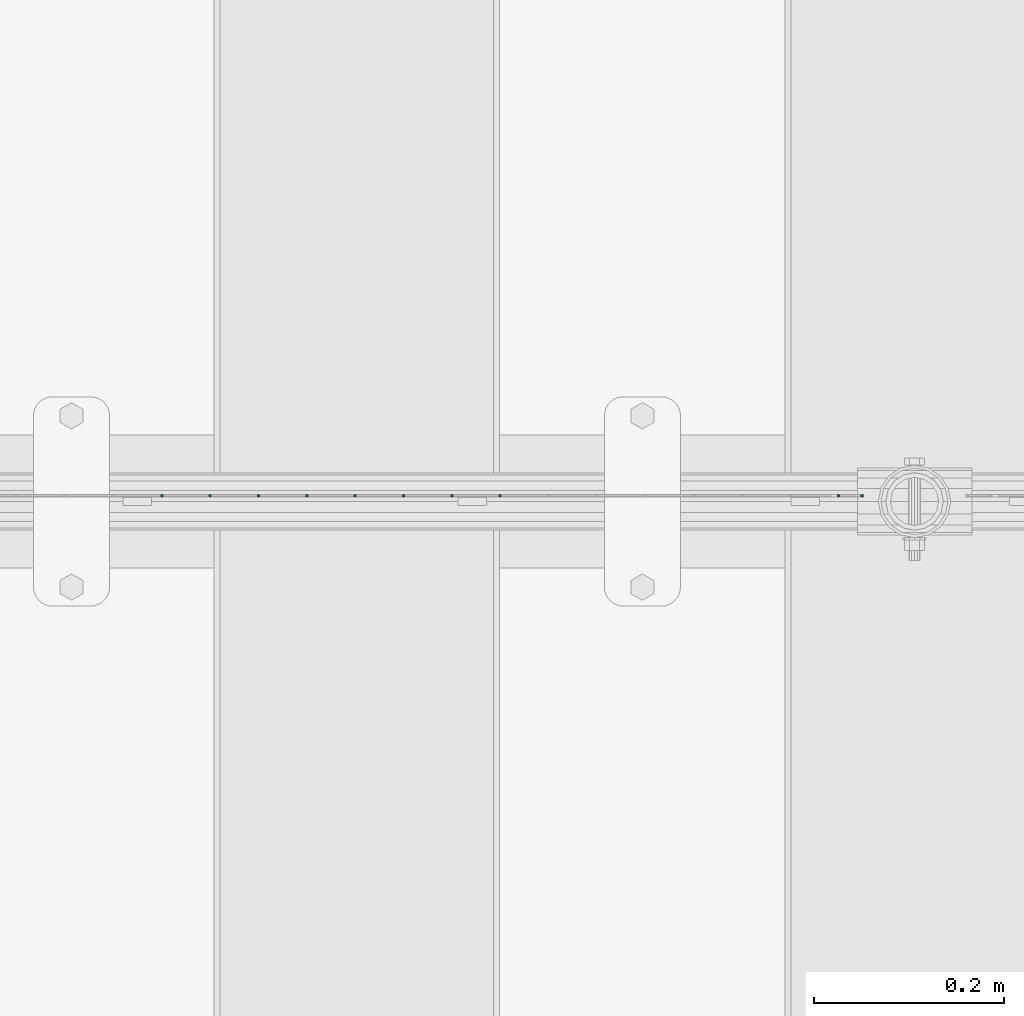
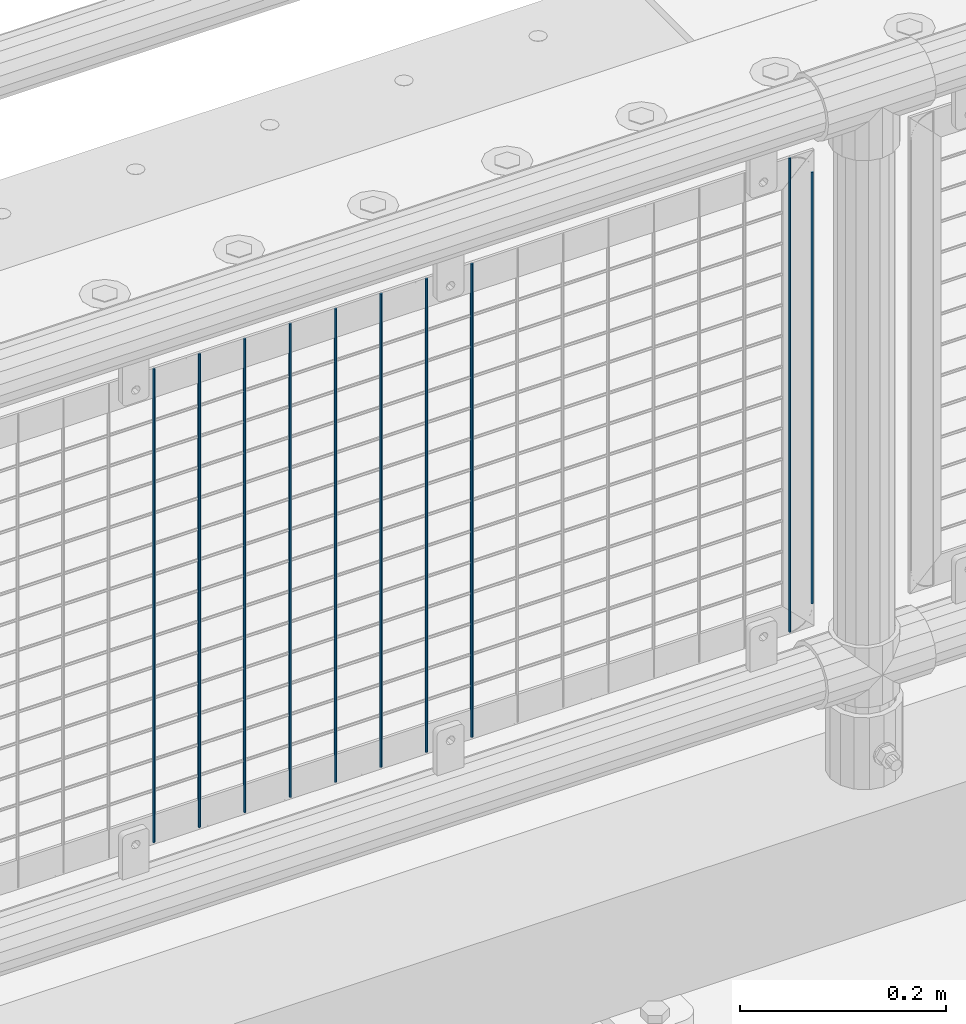
# One storey, part 85 of 270: 10 columns.
"""IFC2X3 building model written with IfcOpenShell, lengths in millimetres."""

from ifc_helpers import new_model, si_unit, frame, origin_with_axes, place, context, subcontext, project, spatial, faceted_brep, material, type_object, element, save


model = new_model("IFC2X3")

# Units and contexts
model_context = context("Model", 3, precision=1e-05, world=origin_with_axes())
body_context = subcontext(model_context, "Body", "Model", "MODEL_VIEW")
ifc_project = project(units=[si_unit("LENGTHUNIT", "METRE", prefix="MILLI"), si_unit("AREAUNIT", "SQUARE_METRE"), si_unit("VOLUMEUNIT", "CUBIC_METRE"), si_unit("MASSUNIT", "GRAM", prefix="KILO"), si_unit("TIMEUNIT", "SECOND"), si_unit("PLANEANGLEUNIT", "RADIAN"), si_unit("SOLIDANGLEUNIT", "STERADIAN"), si_unit("THERMODYNAMICTEMPERATUREUNIT", "DEGREE_CELSIUS"), si_unit("LUMINOUSINTENSITYUNIT", "LUMEN")], contexts=[model_context])

# Site, building, storey
site_placement = place(None, origin_with_axes())
site = spatial("IfcSite", under=ifc_project, at=site_placement, CompositionType="ELEMENT")
building_placement = place(site_placement, origin_with_axes())
building = spatial("IfcBuilding", under=site, at=building_placement, Name="Standard", CompositionType="ELEMENT")
storey_placement = place(building_placement, origin_with_axes())
storey = spatial("IfcBuildingStorey", under=building, at=storey_placement, Name="Undefined", CompositionType="ELEMENT", Elevation=0.0)

# Columns
ifc_material = material(Name="Misc_Undefined")
column_type = type_object("IfcColumnType", Name="D3", PredefinedType="NOTDEFINED")
for number, where, z_axis, x_axis in (
    (1, (8350.446, -16329.5, 353.02), (-1.0, 0.0, 0.0), (0.0, 0.0, 1.0)),
    (2, (8705.997, -16329.5, 353.02), (-1.0, 0.0, 0.0), (0.0, 0.0, 1.0)),
    (3, (8299.653, -16329.5, 353.02), (-1.0, 0.0, 0.0), (0.0, 0.0, 1.0)),
    (4, (8248.86, -16329.5, 353.02), (-1.0, 0.0, 0.0), (0.0, 0.0, 1.0)),
    (5, (8198.067, -16329.5, 353.02), (-1.0, 0.0, 0.0), (0.0, 0.0, 1.0)),
    (6, (8147.274, -16329.5, 353.02), (-1.0, 0.0, 0.0), (0.0, 0.0, 1.0)),
    (7, (8096.481, -16329.5, 353.02), (-1.0, 0.0, 0.0), (0.0, 0.0, 1.0)),
    (8, (8045.688, -16329.5, 353.02), (-1.0, 0.0, 0.0), (0.0, 0.0, 1.0)),
    (9, (7994.895, -16329.5, 353.02), (-1.0, 0.0, 0.0), (0.0, 0.0, 1.0)),
):
    element("IfcColumn", number, at=place(storey_placement, frame(where, z_axis=z_axis, x_axis=x_axis)), inside=storey, type_object=column_type, material=ifc_material, ObjectType="D3", context=body_context, shape_type="Brep", body=[
        faceted_brep([(0.0, -1.5, 0.0), (0.0, -0.75, -1.29903810567669), (560.0, -0.75, -1.29903810567703), (560.0, -1.5, 0.0), (0.0, 0.75, -1.29903810567669), (560.0, 0.75, -1.29903810567703), (0.0, 1.5, 0.0), (560.0, 1.5, 0.0), (0.0, 0.75, 1.29903810567669), (560.0, 0.75, 1.29903810567703), (0.0, -0.75, 1.29903810567669), (560.0, -0.75, 1.29903810567703)], [[[0, 1, 2, 3]], [[1, 4, 5, 2]], [[4, 6, 7, 5]], [[6, 8, 9, 7]], [[8, 10, 11, 9]], [[10, 0, 3, 11]], [[5, 7, 9, 11, 3, 2]], [[10, 8, 6, 4, 1, 0]]]),
    ])
column_placement = place(storey_placement, frame((8731.0, -16329.5, 378.02), z_axis=(-1.0, 0.0, 0.0), x_axis=(0.0, 0.0, 1.0)))
element("IfcColumn", 10, at=column_placement, inside=storey, type_object=column_type, material=ifc_material, ObjectType="D3", context=body_context, shape_type="Brep", body=[
    faceted_brep([(0.0, -1.5, 0.0), (0.0, -0.75, -1.29903810567669), (510.0, -0.75, -1.29903810567703), (510.0, -1.5, 0.0), (0.0, 0.75, -1.29903810567669), (510.0, 0.75, -1.29903810567703), (0.0, 1.5, 0.0), (510.0, 1.5, 0.0), (0.0, 0.75, 1.29903810567669), (510.0, 0.75, 1.29903810567703), (0.0, -0.75, 1.29903810567669), (510.0, -0.75, 1.29903810567703)], [[[0, 1, 2, 3]], [[1, 4, 5, 2]], [[4, 6, 7, 5]], [[6, 8, 9, 7]], [[8, 10, 11, 9]], [[10, 0, 3, 11]], [[5, 7, 9, 11, 3, 2]], [[10, 8, 6, 4, 1, 0]]]),
])

save(model, "model.ifc")
